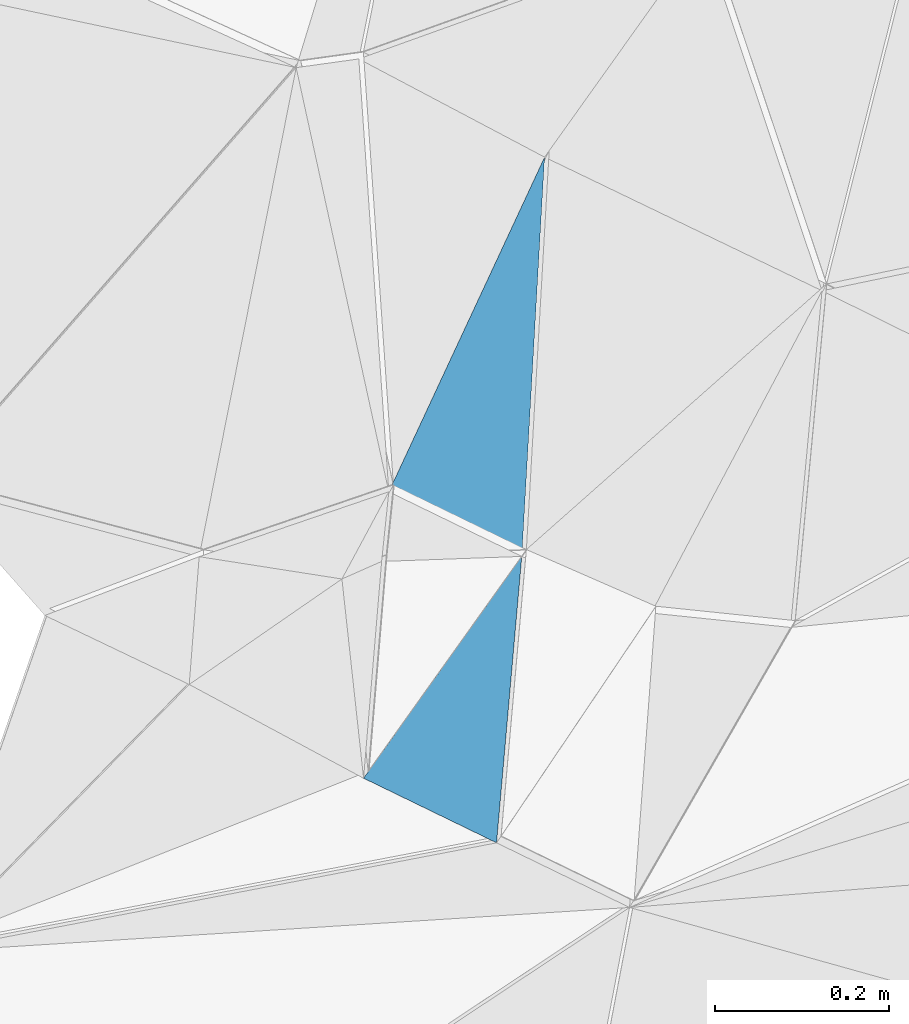
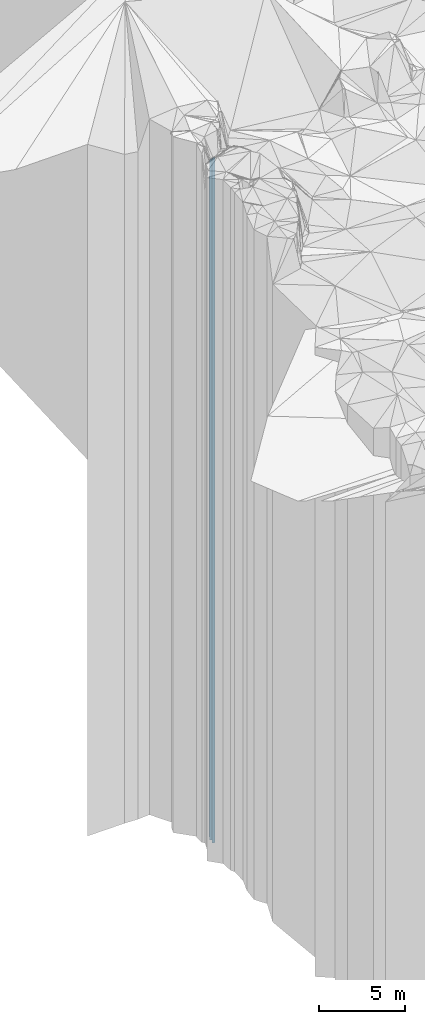
# One storey, part 234 of 275: 2 plates.
"""IFC2X3 building model written with IfcOpenShell, lengths in millimetres."""

from ifc_helpers import new_model, si_unit, frame, origin_with_axes, place, context, subcontext, project, spatial, faceted_brep, material, type_object, element, save


model = new_model("IFC2X3")

# Units and contexts
model_context = context("Model", 3, precision=1e-05, world=origin_with_axes())
body_context = subcontext(model_context, "Body", "Model", "MODEL_VIEW")
ifc_project = project(units=[si_unit("LENGTHUNIT", "METRE", prefix="MILLI"), si_unit("AREAUNIT", "SQUARE_METRE"), si_unit("VOLUMEUNIT", "CUBIC_METRE"), si_unit("MASSUNIT", "GRAM", prefix="KILO"), si_unit("TIMEUNIT", "SECOND"), si_unit("PLANEANGLEUNIT", "RADIAN"), si_unit("SOLIDANGLEUNIT", "STERADIAN"), si_unit("THERMODYNAMICTEMPERATUREUNIT", "DEGREE_CELSIUS"), si_unit("LUMINOUSINTENSITYUNIT", "LUMEN")], contexts=[model_context])

# Site, building, storey
site_placement = place(None, origin_with_axes())
site = spatial("IfcSite", under=ifc_project, at=site_placement, CompositionType="ELEMENT")
building_placement = place(site_placement, origin_with_axes())
building = spatial("IfcBuilding", under=site, at=building_placement, Name="Undefined", CompositionType="ELEMENT")
storey_placement = place(building_placement, origin_with_axes())
storey = spatial("IfcBuildingStorey", under=building, at=storey_placement, Name="Undefined", CompositionType="ELEMENT", Elevation=0.0)

# Plates
ifc_material = material()
plate_type_1 = type_object("IfcPlateType", PredefinedType="NOTDEFINED")
plate_1_placement = place(storey_placement, frame((-137703.729639487, 92067.1442121181, 31074.0), z_axis=(0.436964148096435, 0.899478923198513, 0.0), x_axis=(0.899478923198496, -0.43696414809647, 0.0)))
element("IfcPlate", 1, at=plate_1_placement, inside=storey, type_object=plate_type_1, material=ifc_material, Name="00", context=body_context, shape_type="Brep", body=[
    faceted_brep([(7.27595761418343e-12, -25246.0, 0.0), (-7.04664278036216, -23246.0, 425.147430419896), (-7.04664278036216, 23246.0, 425.147430419896), (1.09139364212751e-11, 23246.0, 2.91038304567337e-11), (170.293869018526, -25426.0, 1.26965460367501e-09), (170.293869018526, 23246.0, 1.26965460367501e-09)], [[[0, 1, 2, 3]], [[1, 4, 5, 2]], [[4, 0, 3, 5]], [[5, 3, 2]], [[4, 1, 0]]]),
])
plate_type_2 = type_object("IfcPlateType", PredefinedType="NOTDEFINED")
plate_2_placement = place(storey_placement, frame((-137550.553898395, 91992.7318990184, 32164.0), z_axis=(0.814155732062535, -0.580646574044588, 0.0), x_axis=(-0.580646574044615, -0.814155732062516, 0.0)))
element("IfcPlate", 2, at=plate_2_placement, inside=storey, type_object=plate_type_2, material=ifc_material, Name="00", context=body_context, shape_type="Brep", body=[
    faceted_brep([(0.0, -24336.0, 1.81898940354586e-11), (285.489349365243, -24576.0, 167.91616821292), (285.489349365243, 24336.0, 167.91616821292), (1.20508047984913e-11, 24336.0, 0.0), (313.847106933587, -24456.0, 2.44472175836563e-09), (313.847106933587, 24336.0, 2.44472175836563e-09)], [[[0, 1, 2, 3]], [[1, 4, 5, 2]], [[4, 0, 3, 5]], [[5, 3, 2]], [[4, 1, 0]]]),
])

save(model, "model.ifc")
